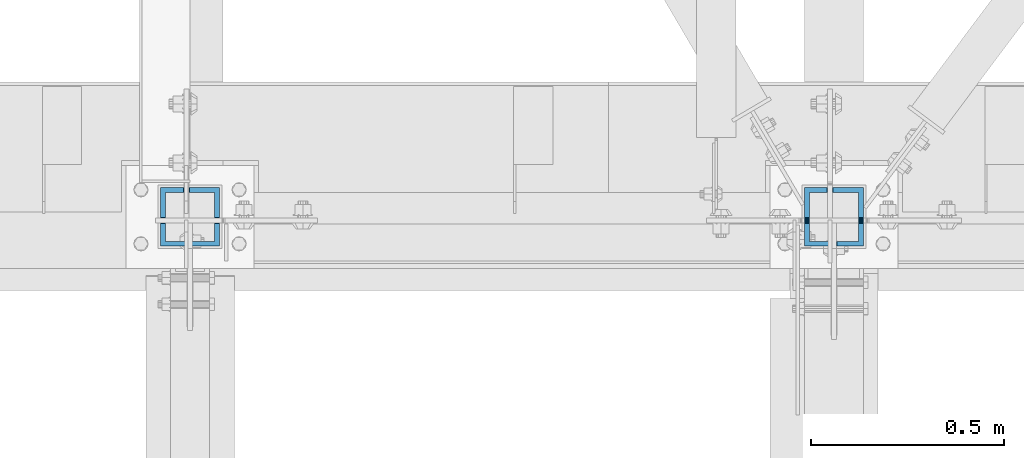
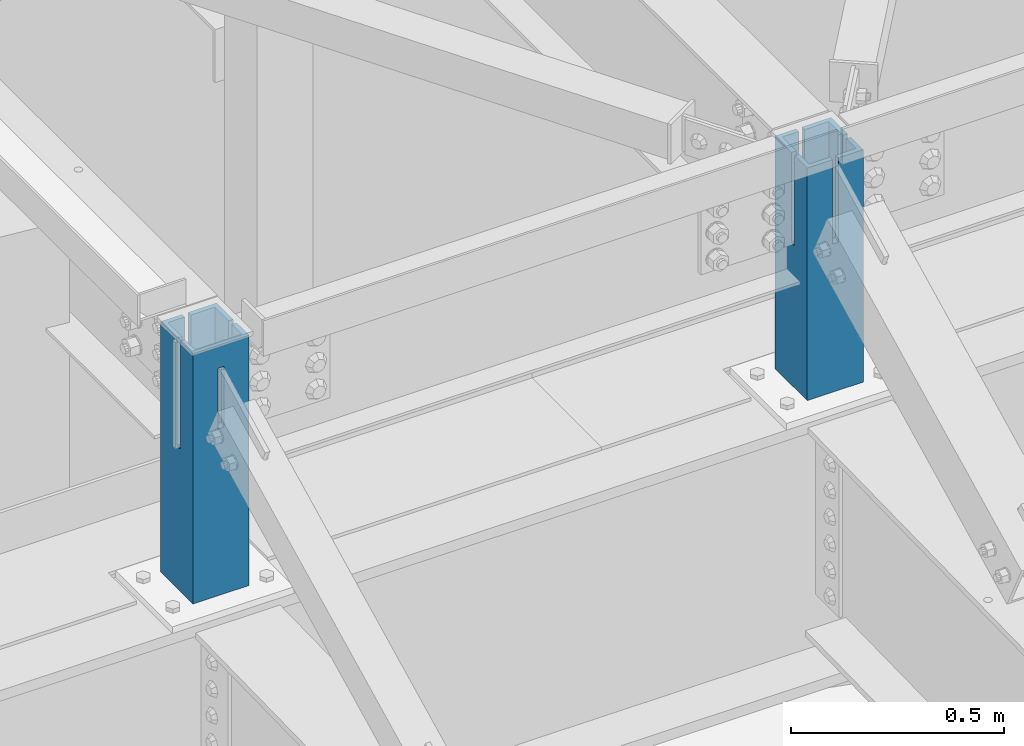
# One storey, part 955 of 1763: 2 columns, 2 elements without a shape of their own.
"""IFC2X3 building model written with IfcOpenShell, lengths in millimetres."""

from ifc_helpers import new_model, si_unit, frame, origin_with_axes, place, context, subcontext, project, spatial, faceted_brep, material, type_object, element, aggregate, save


model = new_model("IFC2X3")

# Units and contexts
model_context = context("Model", 3, precision=1e-05, world=origin_with_axes())
body_context = subcontext(model_context, "Body", "Model", "MODEL_VIEW")
ifc_project = project(units=[si_unit("LENGTHUNIT", "METRE", prefix="MILLI"), si_unit("AREAUNIT", "SQUARE_METRE"), si_unit("VOLUMEUNIT", "CUBIC_METRE"), si_unit("MASSUNIT", "GRAM", prefix="KILO"), si_unit("TIMEUNIT", "SECOND"), si_unit("PLANEANGLEUNIT", "RADIAN"), si_unit("SOLIDANGLEUNIT", "STERADIAN"), si_unit("THERMODYNAMICTEMPERATUREUNIT", "DEGREE_CELSIUS"), si_unit("LUMINOUSINTENSITYUNIT", "LUMEN")], contexts=[model_context])

# Site, building, storey
site_placement = place(None, origin_with_axes())
site = spatial("IfcSite", under=ifc_project, at=site_placement, CompositionType="ELEMENT")
building_placement = place(site_placement, origin_with_axes())
building = spatial("IfcBuilding", under=site, at=building_placement, Name="Undefined", CompositionType="ELEMENT")
storey_placement = place(building_placement, origin_with_axes())
storey = spatial("IfcBuildingStorey", under=building, at=storey_placement, Name="Undefined", CompositionType="ELEMENT", Elevation=0.0)

# Assembly, column
assembly_1_placement = place(storey_placement, origin_with_axes())
assembly_1 = element("IfcElementAssembly", 1, at=assembly_1_placement, inside=storey, Name="COLUMN", AssemblyPlace="NOTDEFINED", PredefinedType="RIGID_FRAME")
ifc_material = material()
column_type = type_object("IfcColumnType", Name="HSS6X6X1/2", PredefinedType="NOTDEFINED")
column_1_placement = place(assembly_1_placement, frame((-41338.5382217781, 52120.800000001, 11747.5), z_axis=(0.0, 1.0, 0.0), x_axis=(0.0, 0.0, 1.0)))
column_1 = element("IfcColumn", 2, at=column_1_placement, type_object=column_type, material=ifc_material, Name="COLUMN", ObjectType="HSS6X6X1/2", context=body_context, shape_type="Brep", body=[
    faceted_brep([(503.595961496601, -7.93750000045475, -63.5), (497.245961042237, -7.93750000045475, -76.1999999999971), (497.245961042237, 7.93749999954525, -76.1999999999971), (503.595961496601, 7.93749999954525, -63.5), (670.996712272654, 7.93749999954525, -76.1999999999971), (670.996712596703, 7.93749999954525, -63.5), (670.996712272654, -7.93750000045475, -76.1999999999971), (670.996712596703, -7.93750000045475, -63.5), (430.349956359118, 63.5, -2.19170621172088), (430.349956359118, 76.2000000000007, -2.19170621172088), (433.387506103516, 76.2000000000007, -1.58750000102737), (433.387506103516, 63.5, -1.58750000102737), (427.774846027847, 63.5, -3.91233992535854), (427.774846027847, 76.2000000000007, -3.91233992535854), (426.054212314208, 63.5, -6.48745025663084), (426.054212314208, 76.2000000000007, -6.48745025663084), (425.450006103516, 63.5, -9.52500000102737), (425.450006103516, 76.2000000000007, -9.52500000102737), (426.054212314208, 63.5, -12.5625497454239), (426.054212314208, 76.2000000000007, -12.5625497454239), (427.774846027847, 63.5, -15.1376600766962), (427.774846027847, 76.2000000000007, -15.1376600766962), (430.349956359118, 63.5, -16.8582937903338), (430.349956359118, 76.2000000000007, -16.8582937903338), (433.387506103516, 63.5, -17.4625000010274), (433.387506103516, 76.2000000000007, -17.4625000010274), (736.996875000008, 63.5, -17.4625000010201), (736.996875000008, 76.1999999999971, -17.4625000010201), (479.364013255605, -16.8582937831452, 76.1999999999971), (476.788902924334, -15.1376600695075, 76.1999999999971), (475.068269210695, -12.5625497382352, 76.1999999999971), (474.464063000003, -9.52499999383872, 76.1999999999971), (475.068269210695, -6.48745024944219, 76.1999999999971), (476.788902924334, -3.91233991816989, 76.1999999999971), (479.364013255605, -2.19170620453224, 76.1999999999971), (482.401563000003, -1.58749999383872, 76.1999999999971), (736.996875000008, -1.58749999383872, 76.1999999999971), (736.996875000008, 76.1999999999971, 76.1999999999971), (19.0499917653633, 76.2000000000007, 76.1999999999971), (19.0499917653633, -76.2000000000007, 76.1999999999971), (736.996875000008, -76.1999999999971, 76.1999999999971), (736.996875000008, -17.4624999938387, 76.1999999999971), (482.401563000003, -17.4624999938387, 76.1999999999971), (482.401563000003, -1.58749999383872, 63.5), (736.996875000008, -1.58749999383872, 63.5), (479.364013255605, -2.19170620453224, 63.5), (476.788902924334, -3.91233991816989, 63.5), (475.068269210695, -6.48745024944219, 63.5), (474.464063000003, -9.52499999383872, 63.5), (475.068269210695, -12.5625497382352, 63.5), (476.788902924334, -15.1376600695075, 63.5), (479.364013255605, -16.8582937831452, 63.5), (482.401563000003, -17.4624999938387, 63.5), (736.996875000008, -17.4624999938387, 63.5), (736.996875000008, -63.5, 63.5), (19.0499917653633, -63.5, 63.5), (19.0499917653633, 63.5, 63.5), (736.996875000008, 63.5, 63.5), (736.996875000008, 63.5, -1.58750000102009), (736.996875000008, 76.1999999999971, -1.58750000102009), (736.996875000008, 76.1999999999971, -76.1999999999971), (19.0499917653633, 76.2000000000007, -76.1999999999971), (19.0499917653633, 63.5, -63.5), (736.996875000008, 63.5, -63.5), (19.0499917653633, -63.5, -63.5), (736.996875000008, -63.5, -63.5), (19.0499917653633, -76.2000000000007, -76.1999999999971), (736.996875000008, -76.1999999999971, -76.1999999999971), (736.996875000008, -76.1999999999971, -17.4625000010201), (433.387500000001, -76.2000000000007, -17.4625000010274), (430.349950255602, -76.2000000000007, -16.8582937903338), (427.774839924332, -76.2000000000007, -15.1376600766962), (426.054206210692, -76.2000000000007, -12.5625497454239), (425.450000000001, -76.2000000000007, -9.52500000102737), (426.054206210692, -76.2000000000007, -6.48745025663084), (427.774839924332, -76.2000000000007, -3.91233992535854), (430.349950255602, -76.2000000000007, -2.19170621172088), (433.387500000001, -76.2000000000007, -1.58750000102737), (736.996875000008, -76.1999999999971, -1.58750000102009), (736.996875000008, -63.5, -1.58750000102009), (430.349950255602, -63.5, -2.19170621172088), (427.774839924332, -63.5, -3.91233992535854), (426.054206210692, -63.5, -6.48745025663084), (425.450000000001, -63.5, -9.52500000102737), (426.054206210692, -63.5, -12.5625497454239), (427.774839924332, -63.5, -15.1376600766962), (430.349950255602, -63.5, -16.8582937903338), (433.387500000001, -63.5, -17.4625000010274), (736.996875000008, -63.5, -17.4625000010201), (433.387500000001, -63.5, -1.58750000102737)], [[[0, 1, 2, 3]], [[3, 2, 4, 5]], [[5, 4, 6, 7]], [[1, 0, 7, 6]], [[8, 9, 10, 11]], [[12, 13, 9, 8]], [[14, 15, 13, 12]], [[16, 17, 15, 14]], [[18, 19, 17, 16]], [[20, 21, 19, 18]], [[22, 23, 21, 20]], [[24, 25, 23, 22]], [[26, 27, 25, 24]], [[28, 29, 30, 31, 32, 33, 34, 35, 36, 37, 38, 39, 40, 41, 42]], [[36, 35, 43, 44]], [[34, 45, 43, 35]], [[33, 46, 45, 34]], [[32, 47, 46, 33]], [[31, 48, 47, 32]], [[30, 49, 48, 31]], [[29, 50, 49, 30]], [[28, 51, 50, 29]], [[42, 52, 51, 28]], [[41, 53, 52, 42]], [[54, 55, 56, 57, 44, 43, 45, 46, 47, 48, 49, 50, 51, 52, 53]], [[37, 36, 44, 57, 58, 59]], [[9, 13, 15, 17, 19, 21, 23, 25, 27, 60, 61, 38, 37, 59, 10]], [[58, 11, 10, 59]], [[57, 56, 62, 63, 26, 24, 22, 20, 18, 16, 14, 12, 8, 11, 58]], [[62, 64, 65, 63], [3, 5, 7, 0]], [[66, 39, 38, 61], [56, 55, 64, 62]], [[40, 39, 66, 67, 68, 69, 70, 71, 72, 73, 74, 75, 76, 77, 78]], [[54, 53, 41, 40, 78, 79]], [[80, 81, 82, 83, 84, 85, 86, 87, 88, 65, 64, 55, 54, 79, 89]], [[78, 77, 89, 79]], [[76, 80, 89, 77]], [[75, 81, 80, 76]], [[74, 82, 81, 75]], [[73, 83, 82, 74]], [[72, 84, 83, 73]], [[71, 85, 84, 72]], [[70, 86, 85, 71]], [[69, 87, 86, 70]], [[68, 88, 87, 69]], [[67, 60, 27, 26, 63, 65, 88, 68]], [[66, 61, 60, 67], [2, 1, 6, 4]]]),
])
aggregate(assembly_1, [column_1])

assembly_2_placement = place(storey_placement, origin_with_axes())
assembly_2 = element("IfcElementAssembly", 3, at=assembly_2_placement, inside=storey, Name="COLUMN", AssemblyPlace="NOTDEFINED", PredefinedType="RIGID_FRAME")
column_2_placement = place(assembly_2_placement, frame((-39672.2896174465, 52120.800000001, 11747.5), z_axis=(0.0, 1.0, 0.0), x_axis=(0.0, 0.0, 1.0)))
column_2 = element("IfcColumn", 4, at=column_2_placement, type_object=column_type, material=ifc_material, Name="COLUMN", ObjectType="HSS6X6X1/2", context=body_context, shape_type="Brep", body=[
    faceted_brep([(685.799999999999, -7.93761745023949, -63.5), (685.799999999999, -7.93761745023949, -76.1999999999971), (673.993766995529, -7.9375000018772, -76.1999999999971), (673.993766939147, -7.9375000018772, -63.5), (685.799999999999, 7.93738254976051, -63.5), (673.993766939147, 7.9374999981228, -63.5), (673.993766995529, 7.9374999981228, -76.1999999999971), (685.799999999999, 7.93738254976051, -76.1999999999971), (430.349956359118, 63.5, -2.19170621172088), (430.349956359118, 76.2000000000007, -2.19170621172088), (433.387506103516, 76.2000000000007, -1.58750000102737), (433.387506103516, 63.5, -1.58750000102737), (427.774846027847, 63.5, -3.91233992535854), (427.774846027847, 76.2000000000007, -3.91233992535854), (426.054212314208, 63.5, -6.48745025663084), (426.054212314208, 76.2000000000007, -6.48745025663084), (425.450006103516, 63.5, -9.52500000102737), (425.450006103516, 76.2000000000007, -9.52500000102737), (426.054212314208, 63.5, -12.5625497454239), (426.054212314208, 76.2000000000007, -12.5625497454239), (427.774846027847, 63.5, -15.1376600766962), (427.774846027847, 76.2000000000007, -15.1376600766962), (430.349956359118, 63.5, -16.8582937903338), (430.349956359118, 76.2000000000007, -16.8582937903338), (433.387506103516, 63.5, -17.4625000010274), (433.387506103516, 76.2000000000007, -17.4625000010274), (685.799999999999, 63.5, -17.4625000010274), (685.799999999999, 76.2000000000007, -17.4625000010274), (19.0499917653633, -76.2000000000007, -76.1999999999971), (19.0499917653633, -76.2000000000007, 76.1999999999971), (19.0499917653633, 76.2000000000007, 76.1999999999971), (19.0499917653633, 76.2000000000007, -76.1999999999971), (19.0499917653633, 63.5, 63.5), (19.0499917653633, -63.5, 63.5), (19.0499917653633, -63.5, -63.5), (19.0499917653633, 63.5, -63.5), (685.799999999999, -76.2000000000007, 76.1999999999971), (685.799999999999, -76.2000000000007, -76.1999999999971), (685.799999999999, -76.2000000000007, -17.4625000010274), (433.387500000001, -76.2000000000007, -17.4625000010274), (430.349950255602, -76.2000000000007, -16.8582937903338), (427.774839924332, -76.2000000000007, -15.1376600766962), (426.054206210692, -76.2000000000007, -12.5625497454239), (425.450000000001, -76.2000000000007, -9.52500000102737), (426.054206210692, -76.2000000000007, -6.48745025663084), (427.774839924332, -76.2000000000007, -3.91233992535854), (430.349950255602, -76.2000000000007, -2.19170621172088), (433.387500000001, -76.2000000000007, -1.58750000102737), (685.799999999999, -76.2000000000007, -1.58750000102737), (685.799999999999, -63.5, -17.4625000010274), (433.387500000001, -63.5, -17.4625000010274), (430.349950255602, -63.5, -16.8582937903338), (427.774839924332, -63.5, -15.1376600766962), (426.054206210692, -63.5, -12.5625497454239), (425.450000000001, -63.5, -9.52500000102737), (426.054206210692, -63.5, -6.48745025663084), (427.774839924332, -63.5, -3.91233992535854), (430.349950255602, -63.5, -2.19170621172088), (433.387500000001, -63.5, -1.58750000102737), (685.799999999999, -63.5, -1.58750000102737), (685.799999999999, -63.5, -63.5), (685.799999999999, -63.5, 63.5), (685.799999999999, -18.2562499943524, 63.5), (685.799999999999, -18.2562499943524, 76.1999999999971), (274.774950255602, -17.6520437836589, 76.1999999999971), (272.199839924331, -15.9314100700212, 76.1999999999971), (270.479206210692, -13.3562997387489, 76.1999999999971), (269.875, -10.3187499943524, 76.1999999999971), (270.479206210692, -7.28120024995587, 76.1999999999971), (272.199839924331, -4.70608991868357, 76.1999999999971), (274.774950255602, -2.98545620504592, 76.1999999999971), (277.8125, -2.3812499943524, 76.1999999999971), (685.799999999999, -2.3812499943524, 76.1999999999971), (685.799999999999, 76.2000000000007, 76.1999999999971), (277.8125, -18.2562499943524, 76.1999999999971), (274.774950255602, -2.98545620504592, 63.5), (277.8125, -2.3812499943524, 63.5), (272.199839924331, -4.70608991868357, 63.5), (270.479206210692, -7.28120024995587, 63.5), (269.875, -10.3187499943524, 63.5), (270.479206210692, -13.3562997387489, 63.5), (272.199839924331, -15.9314100700212, 63.5), (274.774950255602, -17.6520437836589, 63.5), (277.8125, -18.2562499943524, 63.5), (685.799999999999, 63.5, 63.5), (685.799999999999, -2.3812499943524, 63.5), (685.799999999999, 63.5, -1.58750000102737), (685.799999999999, 76.2000000000007, -1.58750000102737), (685.799999999999, 76.2000000000007, -76.1999999999971), (685.799999999999, 63.5, -63.5), (449.796879124498, 7.9374999981228, -63.5), (443.446878208653, 7.9374999981228, -76.1999999999971), (449.796879124498, -7.9375000018772, -63.5), (443.446878208653, -7.9375000018772, -76.1999999999971)], [[[0, 1, 2, 3]], [[4, 5, 6, 7]], [[8, 9, 10, 11]], [[12, 13, 9, 8]], [[14, 15, 13, 12]], [[16, 17, 15, 14]], [[18, 19, 17, 16]], [[20, 21, 19, 18]], [[22, 23, 21, 20]], [[24, 25, 23, 22]], [[26, 27, 25, 24]], [[28, 29, 30, 31], [32, 33, 34, 35]], [[36, 29, 28, 37, 38, 39, 40, 41, 42, 43, 44, 45, 46, 47, 48]], [[38, 49, 50, 39]], [[39, 50, 51, 40]], [[40, 51, 52, 41]], [[41, 52, 53, 42]], [[42, 53, 54, 43]], [[43, 54, 55, 44]], [[44, 55, 56, 45]], [[45, 56, 57, 46]], [[46, 57, 58, 47]], [[48, 47, 58, 59]], [[57, 56, 55, 54, 53, 52, 51, 50, 49, 60, 34, 33, 61, 59, 58]], [[36, 48, 59, 61, 62, 63]], [[64, 65, 66, 67, 68, 69, 70, 71, 72, 73, 30, 29, 36, 63, 74]], [[70, 75, 76, 71]], [[69, 77, 75, 70]], [[68, 78, 77, 69]], [[67, 79, 78, 68]], [[66, 80, 79, 67]], [[65, 81, 80, 66]], [[64, 82, 81, 65]], [[74, 83, 82, 64]], [[63, 62, 83, 74]], [[61, 33, 32, 84, 85, 76, 75, 77, 78, 79, 80, 81, 82, 83, 62]], [[72, 71, 76, 85]], [[84, 86, 87, 73, 72, 85]], [[9, 13, 15, 17, 19, 21, 23, 25, 27, 88, 31, 30, 73, 87, 10]], [[86, 11, 10, 87]], [[84, 32, 35, 89, 26, 24, 22, 20, 18, 16, 14, 12, 8, 11, 86]], [[88, 27, 26, 89, 4, 7]], [[90, 91, 6, 5]], [[92, 93, 91, 90]], [[93, 92, 3, 2]], [[37, 28, 31, 88, 7, 6, 91, 93, 2, 1]], [[60, 49, 38, 37, 1, 0]], [[92, 90, 5, 4, 89, 35, 34, 60, 0, 3]]]),
])
aggregate(assembly_2, [column_2])

save(model, "model.ifc")
